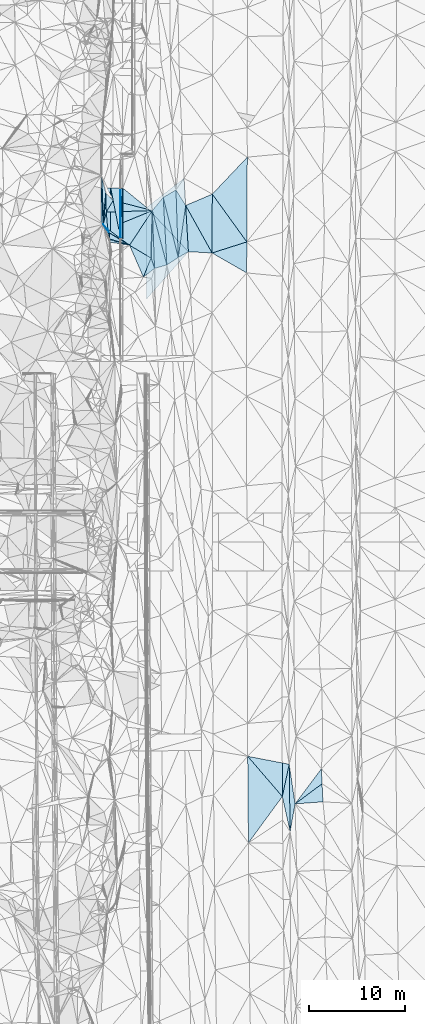
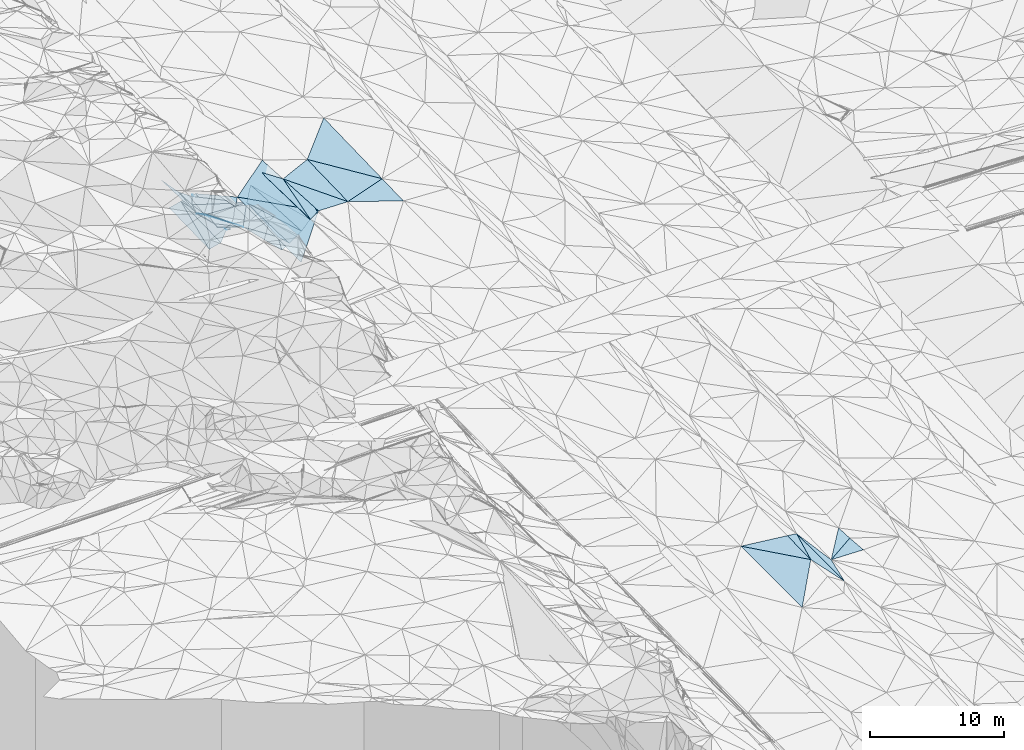
# One storey, part 90 of 275: 45 plates.
"""IFC2X3 building model written with IfcOpenShell, lengths in millimetres."""

from ifc_helpers import new_model, si_unit, frame, origin_with_axes, place, context, subcontext, project, spatial, polyline, outline, extrude, material, type_object, element, save


model = new_model("IFC2X3")

# Units and contexts
model_context = context("Model", 3, precision=1e-05, world=origin_with_axes())
body_context = subcontext(model_context, "Body", "Model", "MODEL_VIEW")
ifc_project = project(units=[si_unit("LENGTHUNIT", "METRE", prefix="MILLI"), si_unit("AREAUNIT", "SQUARE_METRE"), si_unit("VOLUMEUNIT", "CUBIC_METRE"), si_unit("MASSUNIT", "GRAM", prefix="KILO"), si_unit("TIMEUNIT", "SECOND"), si_unit("PLANEANGLEUNIT", "RADIAN"), si_unit("SOLIDANGLEUNIT", "STERADIAN"), si_unit("THERMODYNAMICTEMPERATUREUNIT", "DEGREE_CELSIUS"), si_unit("LUMINOUSINTENSITYUNIT", "LUMEN")], contexts=[model_context])

# Site, building, storey
site_placement = place(None, origin_with_axes())
site = spatial("IfcSite", under=ifc_project, at=site_placement, CompositionType="ELEMENT")
building_placement = place(site_placement, origin_with_axes())
building = spatial("IfcBuilding", under=site, at=building_placement, Name="Undefined", CompositionType="ELEMENT")
storey_placement = place(building_placement, origin_with_axes())
storey = spatial("IfcBuildingStorey", under=building, at=storey_placement, Name="Undefined", CompositionType="ELEMENT", Elevation=0.0)

# Plates
ifc_material = material()
plate_type_1 = type_object("IfcPlateType", PredefinedType="NOTDEFINED")
plate_1_placement = place(storey_placement, frame((-96851.4954738882, 99994.7714658706, 42925.1647417713), z_axis=(0.0499878488941791, 0.021723214804371, -0.998513553689431), x_axis=(-0.00635883793782182, -0.999736246119084, -0.0220681529767121)))
element("IfcPlate", 1, at=plate_1_placement, inside=storey, type_object=plate_type_1, material=ifc_material, Name="00_PR", context=body_context, shape_type="SweptSolid", body=[
    extrude(outline(polyline([(0.0, 0.0), (5080.216796875, 2.57277861237526e-08), (0.0922258049249649, 20.0247631072998), (0.0, 0.0)])), frame((-8.85201319254618e-08, 2.18876761149539e-07, -0.5000001331573), z_axis=(0.0, 0.0, 1.0), x_axis=(1.0, 0.0, 0.0)), (0.0, 0.0, 1.0), 1.0),
])
plate_2_placement = place(storey_placement, frame((-96851.4954738882, 99994.7714658706, 42925.1647417713), z_axis=(0.0499127739263493, 0.0217237749099832, -0.99851729709737), x_axis=(-0.00242106493375147, -0.999757852393647, -0.0218717859771411)))
element("IfcPlate", 2, at=plate_2_placement, inside=storey, type_object=plate_type_1, material=ifc_material, Name="00_PR", context=body_context, shape_type="SweptSolid", body=[
    extrude(outline(polyline([(0.0, 0.0), (5092.08544921875, -1.56724127009511e-08), (5080.17724609375, 20.029857635498), (0.0, 0.0)])), frame((-8.85201319254618e-08, 2.18876761149539e-07, -0.5000001331573), z_axis=(0.0, 0.0, 1.0), x_axis=(1.0, 0.0, 0.0)), (0.0, 0.0, 1.0), 1.0),
])
plate_type_2 = type_object("IfcPlateType", PredefinedType="NOTDEFINED")
plate_3_placement = place(storey_placement, frame((-76033.4313123185, 39794.5600351171, 41820.5024468965), z_axis=(-0.0990305843819008, 0.000980590525737537, -0.995083906913985), x_axis=(0.0417014085437519, -0.999116923871275, -0.00513468202207596)))
element("IfcPlate", 3, at=plate_3_placement, inside=storey, type_object=plate_type_2, material=ifc_material, Name="00", context=body_context, shape_type="SweptSolid", body=[
    extrude(outline(polyline([(0.0, 0.0), (1558.03210449219, -2.21189111471176e-09), (3523.7451171875, 2902.798828125), (0.0, 0.0)])), frame((-8.85201319254618e-08, 2.18876761149539e-07, -0.5000001331573), z_axis=(0.0, 0.0, 1.0), x_axis=(1.0, 0.0, 0.0)), (0.0, 0.0, 1.0), 1.0),
])
plate_type_3 = type_object("IfcPlateType", PredefinedType="NOTDEFINED")
plate_4_placement = place(storey_placement, frame((-90879.428268841, 92799.9130242472, 42942.5060386964), z_axis=(0.153412102929263, 0.0232033825217525, -0.987889836831198), x_axis=(-0.830745012959641, -0.538328156634387, -0.141652812246378)))
element("IfcPlate", 4, at=plate_4_placement, inside=storey, type_object=plate_type_3, material=ifc_material, Name="00", context=body_context, shape_type="SweptSolid", body=[
    extrude(outline(polyline([(0.0, 0.0), (1418.96228027344, 7.27595761418343e-09), (-2051.28784179688, 6090.20556640625), (0.0, 0.0)])), frame((-8.85201319254618e-08, 2.18876761149539e-07, -0.5000001331573), z_axis=(0.0, 0.0, 1.0), x_axis=(1.0, 0.0, 0.0)), (0.0, 0.0, 1.0), 1.0),
])
plate_type_4 = type_object("IfcPlateType", PredefinedType="NOTDEFINED")
plate_5_placement = place(storey_placement, frame((-97871.3958751985, 99997.6725906112, 42674.1790384419), z_axis=(0.242540198046966, 0.0206604415072977, -0.969921336237152), x_axis=(-0.166339082917799, -0.984082270879227, -0.0625571229777207)))
element("IfcPlate", 5, at=plate_5_placement, inside=storey, type_object=plate_type_4, material=ifc_material, Name="00_PR", context=body_context, shape_type="SweptSolid", body=[
    extrude(outline(polyline([(0.0, 0.0), (6096.44384765625, -3.32074705511332e-08), (179.178771972656, 1015.08325195313), (0.0, 0.0)])), frame((-8.85201319254618e-08, 2.18876761149539e-07, -0.5000001331573), z_axis=(0.0, 0.0, 1.0), x_axis=(1.0, 0.0, 0.0)), (0.0, 0.0, 1.0), 1.0),
])
plate_6_placement = place(storey_placement, frame((-98885.4728036614, 93998.2700633974, 42292.803035928), z_axis=(0.242520256274132, 0.0206641242565822, -0.969926244239962), x_axis=(0.166339082916099, 0.98408227087944, 0.0625571229788863)))
element("IfcPlate", 6, at=plate_6_placement, inside=storey, type_object=plate_type_4, material=ifc_material, Name="00_PR", context=body_context, shape_type="SweptSolid", body=[
    extrude(outline(polyline([(0.0, 0.0), (6096.44384765625, -3.32074705511332e-08), (180.159378051758, 1014.90979003906), (0.0, 0.0)])), frame((-8.85201319254618e-08, 2.18876761149539e-07, -0.5000001331573), z_axis=(0.0, 0.0, 1.0), x_axis=(1.0, 0.0, 0.0)), (0.0, 0.0, 1.0), 1.0),
])
plate_type_5 = type_object("IfcPlateType", PredefinedType="NOTDEFINED")
plate_7_placement = place(storey_placement, frame((-96621.4966487298, 99994.1171423472, 42936.6647417637), z_axis=(0.0499878488941791, 0.021723214804371, -0.998513553689431), x_axis=(-0.047538942919173, -0.998578492795067, -0.0241048259330112)))
element("IfcPlate", 7, at=plate_7_placement, inside=storey, type_object=plate_type_5, material=ifc_material, Name="00_PR", context=body_context, shape_type="SweptSolid", body=[
    extrude(outline(polyline([(0.0, 0.0), (5097.44384765625, 2.80706444755197e-08), (10.5577125549316, 230.044937133789), (0.0, 0.0)])), frame((-8.85201319254618e-08, 2.18876761149539e-07, -0.5000001331573), z_axis=(0.0, 0.0, 1.0), x_axis=(1.0, 0.0, 0.0)), (0.0, 0.0, 1.0), 1.0),
])
plate_8_placement = place(storey_placement, frame((-96863.8237934615, 94903.9192835579, 42813.7917395765), z_axis=(0.0498851877388846, 0.0217285145319193, -0.998518572536582), x_axis=(0.0475389429228008, 0.998578492794829, 0.0241048259357086)))
element("IfcPlate", 8, at=plate_8_placement, inside=storey, type_object=plate_type_5, material=ifc_material, Name="00_PR", context=body_context, shape_type="SweptSolid", body=[
    extrude(outline(polyline([(0.0, 0.0), (5097.44384765625, 2.80706444755197e-08), (-126.493705749512, 236.301666259766), (0.0, 0.0)])), frame((-8.85201319254618e-08, 2.18876761149539e-07, -0.5000001331573), z_axis=(0.0, 0.0, 1.0), x_axis=(1.0, 0.0, 0.0)), (0.0, 0.0, 1.0), 1.0),
])
plate_type_6 = type_object("IfcPlateType", PredefinedType="NOTDEFINED")
plate_9_placement = place(storey_placement, frame((-96883.7034717547, 94915.894183728, 42813.068037942), z_axis=(0.242539975016093, 0.0206312405021089, -0.969922013583844), x_axis=(-0.19072077902533, 0.981277901760109, -0.0268190970252547)))
element("IfcPlate", 9, at=plate_9_placement, inside=storey, type_object=plate_type_6, material=ifc_material, Name="00_PR", context=body_context, shape_type="SweptSolid", body=[
    extrude(outline(polyline([(0.0, 0.0), (5178.7353515625, -8.89849616214633e-09), (4978.51904296875, 1011.14544677734), (0.0, 0.0)])), frame((-8.85201319254618e-08, 2.18876761149539e-07, -0.5000001331573), z_axis=(0.0, 0.0, 1.0), x_axis=(1.0, 0.0, 0.0)), (0.0, 0.0, 1.0), 1.0),
])
plate_type_7 = type_object("IfcPlateType", PredefinedType="NOTDEFINED")
plate_10_placement = place(storey_placement, frame((-97885.4748056534, 93996.422001917, 42542.803058005), z_axis=(0.242696475155084, 0.0206627458977623, -0.969882194845983), x_axis=(0.00234544393031738, 0.999757718688224, 0.021886132963307)))
element("IfcPlate", 10, at=plate_10_placement, inside=storey, type_object=plate_type_7, material=ifc_material, Name="00_PR", context=body_context, shape_type="SweptSolid", body=[
    extrude(outline(polyline([(0.0, 0.0), (6002.705078125, 1.50030246004462e-08), (927.514099121094, 1030.40563964844), (0.0, 0.0)])), frame((-8.85201319254618e-08, 2.18876761149539e-07, -0.5000001331573), z_axis=(0.0, 0.0, 1.0), x_axis=(1.0, 0.0, 0.0)), (0.0, 0.0, 1.0), 1.0),
])
plate_type_8 = type_object("IfcPlateType", PredefinedType="NOTDEFINED")
plate_11_placement = place(storey_placement, frame((-90275.6695176249, 101020.000287432, 43130.1992877888), z_axis=(0.0266095090018855, 0.0212499423153103, -0.999420018802042), x_axis=(0.0588251470836311, -0.998074785881558, -0.0196551229472426)))
element("IfcPlate", 11, at=plate_11_placement, inside=storey, type_object=plate_type_8, material=ifc_material, Name="00_PR", context=body_context, shape_type="SweptSolid", body=[
    extrude(outline(polyline([(0.0, 0.0), (7633.7353515625, 1.84372765943408e-08), (2794.35400390625, 4048.16479492188), (0.0, 0.0)])), frame((-8.85201319254618e-08, 2.18876761149539e-07, -0.5000001331573), z_axis=(0.0, 0.0, 1.0), x_axis=(1.0, 0.0, 0.0)), (0.0, 0.0, 1.0), 1.0),
])
plate_type_9 = type_object("IfcPlateType", PredefinedType="NOTDEFINED")
plate_12_placement = place(storey_placement, frame((-94151.0091776219, 97995.1476947049, 42962.7033156838), z_axis=(0.0281719520292118, 0.0217993766161195, -0.999365362766797), x_axis=(-0.609228406898133, -0.792245900997221, -0.0344554869572939)))
element("IfcPlate", 12, at=plate_12_placement, inside=storey, type_object=plate_type_9, material=ifc_material, Name="00_PR", context=body_context, shape_type="SweptSolid", body=[
    extrude(outline(polyline([(0.0, 0.0), (4075.80932617188, -1.4319084584713e-08), (-77.6803970336914, 3177.08740234375), (0.0, 0.0)])), frame((-8.85201319254618e-08, 2.18876761149539e-07, -0.5000001331573), z_axis=(0.0, 0.0, 1.0), x_axis=(1.0, 0.0, 0.0)), (0.0, 0.0, 1.0), 1.0),
])
plate_type_10 = type_object("IfcPlateType", PredefinedType="NOTDEFINED")
plate_13_placement = place(storey_placement, frame((-94147.9699608055, 88514.5299228079, 42755.1683050541), z_axis=(0.0272849131028936, 0.0218858040277872, -0.999388085329731), x_axis=(-0.000320542090710549, 0.999760438789883, 0.0218852069541962)))
element("IfcPlate", 13, at=plate_13_placement, inside=storey, type_object=plate_type_10, material=ifc_material, Name="00_PR", context=body_context, shape_type="SweptSolid", body=[
    extrude(outline(polyline([(0.0, 0.0), (9482.8896484375, 3.57103999704123e-08), (4888.80029296875, 4324.53369140625), (0.0, 0.0)])), frame((-8.85201319254618e-08, 2.18876761149539e-07, -0.5000001331573), z_axis=(0.0, 0.0, 1.0), x_axis=(1.0, 0.0, 0.0)), (0.0, 0.0, 1.0), 1.0),
])
plate_type_11 = type_object("IfcPlateType", PredefinedType="NOTDEFINED")
plate_14_placement = place(storey_placement, frame((-98649.5947140472, 96242.1038516488, 44091.5713644292), z_axis=(0.422697225661851, 0.294101729878889, -0.857222974435484), x_axis=(0.568448481414877, -0.822716524468137, -0.0019606999233459)))
element("IfcPlate", 14, at=plate_14_placement, inside=storey, type_object=plate_type_11, material=ifc_material, Name="00", context=body_context, shape_type="SweptSolid", body=[
    extrude(outline(polyline([(0.0, 0.0), (1020.04364013672, 4.14729584008455e-09), (1615.89074707031, 405.54443359375), (0.0, 0.0)])), frame((-8.85201319254618e-08, 2.18876761149539e-07, -0.5000001331573), z_axis=(0.0, 0.0, 1.0), x_axis=(1.0, 0.0, 0.0)), (0.0, 0.0, 1.0), 1.0),
])
plate_type_12 = type_object("IfcPlateType", PredefinedType="NOTDEFINED")
plate_15_placement = place(storey_placement, frame((-92434.1707186344, 99034.6654672302, 42847.5066312682), z_axis=(0.160589880628025, 0.0250113536539149, -0.986704273036393), x_axis=(0.854186650649069, 0.497366704443762, 0.151629572193809)))
element("IfcPlate", 15, at=plate_15_placement, inside=storey, type_object=plate_type_12, material=ifc_material, Name="00", context=body_context, shape_type="SweptSolid", body=[
    extrude(outline(polyline([(0.0, 0.0), (1543.23461914063, -8.92032403498888e-09), (-1758.50964355469, 6181.1025390625), (0.0, 0.0)])), frame((-8.85201319254618e-08, 2.18876761149539e-07, -0.5000001331573), z_axis=(0.0, 0.0, 1.0), x_axis=(1.0, 0.0, 0.0)), (0.0, 0.0, 1.0), 1.0),
])
plate_type_13 = type_object("IfcPlateType", PredefinedType="NOTDEFINED")
plate_16_placement = place(storey_placement, frame((-98196.1666606624, 95762.4005313073, 44129.5010006608), z_axis=(0.0190056937315234, -0.0611032247328537, -0.997950489519911), x_axis=(-0.686083527377673, 0.725249145473881, -0.057472345092366)))
element("IfcPlate", 16, at=plate_16_placement, inside=storey, type_object=plate_type_13, material=ifc_material, Name="00", context=body_context, shape_type="SweptSolid", body=[
    extrude(outline(polyline([(0.0, 0.0), (661.187561035156, -3.85898601962253e-09), (1374.07299804688, 1102.73449707031), (0.0, 0.0)])), frame((-8.85201319254618e-08, 2.18876761149539e-07, -0.5000001331573), z_axis=(0.0, 0.0, 1.0), x_axis=(1.0, 0.0, 0.0)), (0.0, 0.0, 1.0), 1.0),
])
plate_type_14 = type_object("IfcPlateType", PredefinedType="NOTDEFINED")
plate_17_placement = place(storey_placement, frame((-80085.5916670394, 36916.2967845375, 42099.50017681), z_axis=(0.0189356338819722, 0.0201371554471049, -0.999617895368019), x_axis=(-0.00269947860207132, 0.999794539727684, 0.0200895780440072)))
element("IfcPlate", 17, at=plate_17_placement, inside=storey, type_object=plate_type_14, material=ifc_material, Name="00", context=body_context, shape_type="SweptSolid", body=[
    extrude(outline(polyline([(0.0, 0.0), (3484.39379882813, 8.99308361113071e-09), (3350.90991210938, 720.612976074219), (0.0, 0.0)])), frame((-8.85201319254618e-08, 2.18876761149539e-07, -0.5000001331573), z_axis=(0.0, 0.0, 1.0), x_axis=(1.0, 0.0, 0.0)), (0.0, 0.0, 1.0), 1.0),
])
plate_type_15 = type_object("IfcPlateType", PredefinedType="NOTDEFINED")
plate_18_placement = place(storey_placement, frame((-98649.9176925917, 96241.9566718011, 44091.5125962037), z_axis=(-0.223261227040327, -0.000256070140579247, -0.974758615724186), x_axis=(0.0823128983151945, 0.996423206577544, -0.0191149199495282)))
element("IfcPlate", 18, at=plate_18_placement, inside=storey, type_object=plate_type_15, material=ifc_material, Name="00", context=body_context, shape_type="SweptSolid", body=[
    extrude(outline(polyline([(0.0, 0.0), (3243.53955078125, 2.23517417907715e-08), (1295.81860351563, 212.327789306641), (0.0, 0.0)])), frame((-8.85201319254618e-08, 2.18876761149539e-07, -0.5000001331573), z_axis=(0.0, 0.0, 1.0), x_axis=(1.0, 0.0, 0.0)), (0.0, 0.0, 1.0), 1.0),
])
plate_type_16 = type_object("IfcPlateType", PredefinedType="NOTDEFINED")
plate_19_placement = place(storey_placement, frame((-90879.4937492969, 92799.9125058348, 42942.5002360059), z_axis=(0.0224678788915802, 0.022170608065339, -0.999501705129174), x_axis=(0.141197513269786, 0.989662532799849, 0.0251263490904683)))
element("IfcPlate", 19, at=plate_19_placement, inside=storey, type_object=plate_type_16, material=ifc_material, Name="00", context=body_context, shape_type="SweptSolid", body=[
    extrude(outline(polyline([(0.0, 0.0), (5452.443359375, 3.93920345231891e-08), (744.4296875, 957.60400390625), (0.0, 0.0)])), frame((-8.85201319254618e-08, 2.18876761149539e-07, -0.5000001331573), z_axis=(0.0, 0.0, 1.0), x_axis=(1.0, 0.0, 0.0)), (0.0, 0.0, 1.0), 1.0),
])
plate_type_17 = type_object("IfcPlateType", PredefinedType="NOTDEFINED")
plate_20_placement = place(storey_placement, frame((-94492.9649423907, 90773.847794996, 42619.5155002682), z_axis=(-0.245459050503838, -0.0292562782276308, -0.968965388809127), x_axis=(0.370441277422486, 0.920856099989519, -0.121644165884315)))
element("IfcPlate", 20, at=plate_20_placement, inside=storey, type_object=plate_type_17, material=ifc_material, Name="00", context=body_context, shape_type="SweptSolid", body=[
    extrude(outline(polyline([(0.0, 0.0), (2137.38159179688, -6.25732354819775e-10), (1292.49731445313, 756.409057617188), (0.0, 0.0)])), frame((-8.85201319254618e-08, 2.18876761149539e-07, -0.5000001331573), z_axis=(0.0, 0.0, 1.0), x_axis=(1.0, 0.0, 0.0)), (0.0, 0.0, 1.0), 1.0),
])
plate_type_18 = type_object("IfcPlateType", PredefinedType="NOTDEFINED")
plate_21_placement = place(storey_placement, frame((-95930.3803203107, 94074.5184665174, 43239.5391739433), z_axis=(-0.386706968819318, -0.03320444519937, -0.921604679396528), x_axis=(-0.805013531310506, 0.499692777425539, 0.319781710852481)))
element("IfcPlate", 21, at=plate_21_placement, inside=storey, type_object=plate_type_18, material=ifc_material, Name="00", context=body_context, shape_type="SweptSolid", body=[
    extrude(outline(polyline([(0.0, 0.0), (2658.06323242188, -1.880107447505e-08), (2952.18725585938, 245.746032714844), (0.0, 0.0)])), frame((-8.85201319254618e-08, 2.18876761149539e-07, -0.5000001331573), z_axis=(0.0, 0.0, 1.0), x_axis=(1.0, 0.0, 0.0)), (0.0, 0.0, 1.0), 1.0),
])
plate_type_19 = type_object("IfcPlateType", PredefinedType="NOTDEFINED")
plate_22_placement = place(storey_placement, frame((-98337.0715646821, 97515.2004035247, 44019.5253300945), z_axis=(-0.314366927923119, 0.00429933410968608, -0.949291815172971), x_axis=(0.499715744396123, 0.85097557419745, -0.1616315158685)))
element("IfcPlate", 22, at=plate_22_placement, inside=storey, type_object=plate_type_19, material=ifc_material, Name="00", context=body_context, shape_type="SweptSolid", body=[
    extrude(outline(polyline([(0.0, 0.0), (1422.98986816406, -1.76078174263239e-09), (2769.94946289063, 4202.548828125), (0.0, 0.0)])), frame((-8.85201319254618e-08, 2.18876761149539e-07, -0.5000001331573), z_axis=(0.0, 0.0, 1.0), x_axis=(1.0, 0.0, 0.0)), (0.0, 0.0, 1.0), 1.0),
])
plate_type_20 = type_object("IfcPlateType", PredefinedType="NOTDEFINED")
plate_23_placement = place(storey_placement, frame((-98382.9730452485, 99473.8937754589, 44029.5236812722), z_axis=(-0.304250806936095, -0.00226743097546864, -0.952589263657484), x_axis=(0.693996290290871, -0.685534573345628, -0.220026129835385)))
element("IfcPlate", 23, at=plate_23_placement, inside=storey, type_object=plate_type_20, material=ifc_material, Name="00", context=body_context, shape_type="SweptSolid", body=[
    extrude(outline(polyline([(0.0, 0.0), (1090.77954101563, -5.21140464115888e-09), (1376.8134765625, 1393.94567871094), (0.0, 0.0)])), frame((-8.85201319254618e-08, 2.18876761149539e-07, -0.5000001331573), z_axis=(0.0, 0.0, 1.0), x_axis=(1.0, 0.0, 0.0)), (0.0, 0.0, 1.0), 1.0),
])
plate_type_21 = type_object("IfcPlateType", PredefinedType="NOTDEFINED")
plate_24_placement = place(storey_placement, frame((-98017.5897913264, 94715.4255975981, 43879.5381074966), z_axis=(-0.179340930042034, 0.338448070933907, -0.923736831620768), x_axis=(0.917378437261553, -0.281598334416378, -0.281281319858738)))
element("IfcPlate", 24, at=plate_24_placement, inside=storey, type_object=plate_type_21, material=ifc_material, Name="00", context=body_context, shape_type="SweptSolid", body=[
    extrude(outline(polyline([(0.0, 0.0), (2275.30224609375, -1.02154444903135e-08), (179.668441772461, 305.645629882813), (0.0, 0.0)])), frame((-8.85201319254618e-08, 2.18876761149539e-07, -0.5000001331573), z_axis=(0.0, 0.0, 1.0), x_axis=(1.0, 0.0, 0.0)), (0.0, 0.0, 1.0), 1.0),
])
plate_type_22 = type_object("IfcPlateType", PredefinedType="NOTDEFINED")
plate_25_placement = place(storey_placement, frame((-90879.4892937552, 92799.9118699621, 42942.5003400387), z_axis=(0.0313641220691345, 0.0208959736422015, -0.999289572712723), x_axis=(-0.0337537855506743, 0.999233325797349, 0.0198353869881341)))
element("IfcPlate", 25, at=plate_25_placement, inside=storey, type_object=plate_type_22, material=ifc_material, Name="00", context=body_context, shape_type="SweptSolid", body=[
    extrude(outline(polyline([(0.0, 0.0), (7007.677734375, 3.8911821320653e-08), (5368.67333984375, 952.095703125), (0.0, 0.0)])), frame((-8.85201319254618e-08, 2.18876761149539e-07, -0.5000001331573), z_axis=(0.0, 0.0, 1.0), x_axis=(1.0, 0.0, 0.0)), (0.0, 0.0, 1.0), 1.0),
])
plate_type_23 = type_object("IfcPlateType", PredefinedType="NOTDEFINED")
plate_26_placement = place(storey_placement, frame((-83679.8446833976, 41089.3267892195, 42049.5004338664), z_axis=(0.0373238349353213, 0.0201763877065602, -0.999099516927536), x_axis=(0.981478516190084, -0.188734010393797, 0.0328541561752194)))
element("IfcPlate", 26, at=plate_26_placement, inside=storey, type_object=plate_type_23, material=ifc_material, Name="00", context=body_context, shape_type="SweptSolid", body=[
    extrude(outline(polyline([(0.0, 0.0), (3652.50610351563, 1.17652234621346e-08), (4316.9267578125, 3420.45971679688), (0.0, 0.0)])), frame((-8.85201319254618e-08, 2.18876761149539e-07, -0.5000001331573), z_axis=(0.0, 0.0, 1.0), x_axis=(1.0, 0.0, 0.0)), (0.0, 0.0, 1.0), 1.0),
])
plate_type_24 = type_object("IfcPlateType", PredefinedType="NOTDEFINED")
plate_27_placement = place(storey_placement, frame((-79374.1536429035, 40268.1881923376, 42180.5002223784), z_axis=(0.0240817060204962, 0.0190427497614881, -0.999528611454752), x_axis=(0.0135621845081415, -0.999732780825946, -0.0187198849726488)))
element("IfcPlate", 27, at=plate_27_placement, inside=storey, type_object=plate_type_24, material=ifc_material, Name="00", context=body_context, shape_type="SweptSolid", body=[
    extrude(outline(polyline([(0.0, 0.0), (6997.90625, 2.26573320105672e-08), (3342.86401367188, 757.061218261719), (0.0, 0.0)])), frame((-8.85201319254618e-08, 2.18876761149539e-07, -0.5000001331573), z_axis=(0.0, 0.0, 1.0), x_axis=(1.0, 0.0, 0.0)), (0.0, 0.0, 1.0), 1.0),
])
plate_type_25 = type_object("IfcPlateType", PredefinedType="NOTDEFINED")
plate_28_placement = place(storey_placement, frame((-98337.0697489859, 97515.1560691167, 44019.5266037524), z_axis=(-0.310738305127826, -0.0843663590170433, -0.946743905812176), x_axis=(0.948919039932134, 0.0298080286263581, -0.31410847980226)))
element("IfcPlate", 28, at=plate_28_placement, inside=storey, type_object=plate_type_25, material=ifc_material, Name="00", context=body_context, shape_type="SweptSolid", body=[
    extrude(outline(polyline([(0.0, 0.0), (5033.29296875, -1.68511178344488e-08), (46.7507057189941, 1761.22521972656), (0.0, 0.0)])), frame((-8.85201319254618e-08, 2.18876761149539e-07, -0.5000001331573), z_axis=(0.0, 0.0, 1.0), x_axis=(1.0, 0.0, 0.0)), (0.0, 0.0, 1.0), 1.0),
])
plate_type_26 = type_object("IfcPlateType", PredefinedType="NOTDEFINED")
plate_29_placement = place(storey_placement, frame((-92058.141845711, 92036.0509957487, 42741.5262353148), z_axis=(0.317963398408484, 0.0338635516200331, -0.947498040707317), x_axis=(-0.91225614845957, -0.261274519448484, -0.315474793105052)))
element("IfcPlate", 29, at=plate_29_placement, inside=storey, type_object=plate_type_26, material=ifc_material, Name="00", context=body_context, shape_type="SweptSolid", body=[
    extrude(outline(polyline([(0.0, 0.0), (1401.06286621094, 1.74622982740402e-09), (-4.57938051223755, 5834.11767578125), (0.0, 0.0)])), frame((-8.85201319254618e-08, 2.18876761149539e-07, -0.5000001331573), z_axis=(0.0, 0.0, 1.0), x_axis=(1.0, 0.0, 0.0)), (0.0, 0.0, 1.0), 1.0),
])
plate_type_27 = type_object("IfcPlateType", PredefinedType="NOTDEFINED")
plate_30_placement = place(storey_placement, frame((-93560.7806803671, 97665.2403059173, 42438.5029726797), z_axis=(-0.107640898675959, 0.0190189408115221, -0.994007905814959), x_axis=(0.0373763636439471, -0.999032783804082, -0.0231625630149665)))
element("IfcPlate", 30, at=plate_30_placement, inside=storey, type_object=plate_type_27, material=ifc_material, Name="00", context=body_context, shape_type="SweptSolid", body=[
    extrude(outline(polyline([(0.0, 0.0), (6001.06298828125, 1.16560840979218e-08), (4914.97021484375, 326.169006347656), (0.0, 0.0)])), frame((-8.85201319254618e-08, 2.18876761149539e-07, -0.5000001331573), z_axis=(0.0, 0.0, 1.0), x_axis=(1.0, 0.0, 0.0)), (0.0, 0.0, 1.0), 1.0),
])
plate_type_28 = type_object("IfcPlateType", PredefinedType="NOTDEFINED")
plate_31_placement = place(storey_placement, frame((-98649.9544002038, 96241.9598922644, 44091.522487426), z_axis=(-0.296575916229426, 0.00617958200956695, -0.954989287206335), x_axis=(-0.0366512435666968, 0.999168728235892, 0.0178476570026558)))
element("IfcPlate", 31, at=plate_31_placement, inside=storey, type_object=plate_type_28, material=ifc_material, Name="00", context=body_context, shape_type="SweptSolid", body=[
    extrude(outline(polyline([(0.0, 0.0), (5098.70849609375, -2.76850187219679e-08), (3218.35961914063, 403.373901367188), (0.0, 0.0)])), frame((-8.85201319254618e-08, 2.18876761149539e-07, -0.5000001331573), z_axis=(0.0, 0.0, 1.0), x_axis=(1.0, 0.0, 0.0)), (0.0, 0.0, 1.0), 1.0),
])
plate_type_29 = type_object("IfcPlateType", PredefinedType="NOTDEFINED")
plate_32_placement = place(storey_placement, frame((-98649.6570487138, 96242.0609066023, 44091.534211901), z_axis=(0.298130104071669, 0.208210326005475, -0.931540069557348), x_axis=(0.686083527316686, -0.72524914552902, 0.0574723451245978)))
element("IfcPlate", 32, at=plate_32_placement, inside=storey, type_object=plate_type_29, material=ifc_material, Name="00", context=body_context, shape_type="SweptSolid", body=[
    extrude(outline(polyline([(0.0, 0.0), (661.187561035156, -3.85898601962253e-09), (1006.33923339844, 166.644287109375), (0.0, 0.0)])), frame((-8.85201319254618e-08, 2.18876761149539e-07, -0.5000001331573), z_axis=(0.0, 0.0, 1.0), x_axis=(1.0, 0.0, 0.0)), (0.0, 0.0, 1.0), 1.0),
])
plate_type_30 = type_object("IfcPlateType", PredefinedType="NOTDEFINED")
plate_33_placement = place(storey_placement, frame((-95930.3639975991, 94074.5476165784, 43239.5325345914), z_axis=(-0.354067786176836, 0.0250949145029904, -0.93488301303314), x_axis=(0.541471896270453, 0.820550140971885, -0.183045490794772)))
element("IfcPlate", 33, at=plate_33_placement, inside=storey, type_object=plate_type_30, material=ifc_material, Name="00", context=body_context, shape_type="SweptSolid", body=[
    extrude(outline(polyline([(0.0, 0.0), (4375.96142578125, 1.29803083837032e-08), (274.741912841797, 2728.24438476563), (0.0, 0.0)])), frame((-8.85201319254618e-08, 2.18876761149539e-07, -0.5000001331573), z_axis=(0.0, 0.0, 1.0), x_axis=(1.0, 0.0, 0.0)), (0.0, 0.0, 1.0), 1.0),
])
plate_type_31 = type_object("IfcPlateType", PredefinedType="NOTDEFINED")
plate_34_placement = place(storey_placement, frame((-95930.2894420905, 94074.6708651651, 43239.5298080339), z_axis=(-0.204952536480822, 0.271592347513673, -0.940336139134347), x_axis=(-0.917378437262476, 0.281598334411352, 0.281281319860756)))
element("IfcPlate", 34, at=plate_34_placement, inside=storey, type_object=plate_type_31, material=ifc_material, Name="00", context=body_context, shape_type="SweptSolid", body=[
    extrude(outline(polyline([(0.0, 0.0), (2275.30224609375, -1.02154444903135e-08), (2576.09741210938, 654.997863769531), (0.0, 0.0)])), frame((-8.85201319254618e-08, 2.18876761149539e-07, -0.5000001331573), z_axis=(0.0, 0.0, 1.0), x_axis=(1.0, 0.0, 0.0)), (0.0, 0.0, 1.0), 1.0),
])
plate_type_32 = type_object("IfcPlateType", PredefinedType="NOTDEFINED")
plate_35_placement = place(storey_placement, frame((-95930.3653160366, 94074.5451246657, 43239.532974765), z_axis=(-0.356698997450711, 0.0201117558335373, -0.934002860003624), x_axis=(0.812940984372365, -0.485933943464254, -0.32092858787738)))
element("IfcPlate", 35, at=plate_35_placement, inside=storey, type_object=plate_type_32, material=ifc_material, Name="00", context=body_context, shape_type="SweptSolid", body=[
    extrude(outline(polyline([(0.0, 0.0), (2742.04296875, 2.37923813983798e-09), (2971.36108398438, 2125.04418945313), (0.0, 0.0)])), frame((-8.85201319254618e-08, 2.18876761149539e-07, -0.5000001331573), z_axis=(0.0, 0.0, 1.0), x_axis=(1.0, 0.0, 0.0)), (0.0, 0.0, 1.0), 1.0),
])
plate_type_33 = type_object("IfcPlateType", PredefinedType="NOTDEFINED")
plate_36_placement = place(storey_placement, frame((-98196.3515715049, 95762.44241289, 44129.5318905529), z_axis=(-0.35081474585774, 0.0226610265390312, -0.9361706532278), x_axis=(0.876526140599326, 0.359804105483713, -0.31975448475841)))
element("IfcPlate", 36, at=plate_36_placement, inside=storey, type_object=plate_type_33, material=ifc_material, Name="00", context=body_context, shape_type="SweptSolid", body=[
    extrude(outline(polyline([(0.0, 0.0), (5288.4326171875, 2.06346157938242e-08), (1663.46838378906, 2451.25952148438), (0.0, 0.0)])), frame((-8.85201319254618e-08, 2.18876761149539e-07, -0.5000001331573), z_axis=(0.0, 0.0, 1.0), x_axis=(1.0, 0.0, 0.0)), (0.0, 0.0, 1.0), 1.0),
])
plate_type_34 = type_object("IfcPlateType", PredefinedType="NOTDEFINED")
plate_37_placement = place(storey_placement, frame((-90109.621730295, 98195.9911449899, 43079.5002384487), z_axis=(0.0235561188514083, 0.0211994500393164, -0.99949772014882), x_axis=(0.91950303106459, 0.391937679776366, 0.0299838462267529)))
element("IfcPlate", 37, at=plate_37_placement, inside=storey, type_object=plate_type_34, material=ifc_material, Name="00", context=body_context, shape_type="SweptSolid", body=[
    extrude(outline(polyline([(0.0, 0.0), (3001.6162109375, 4.30736690759659e-09), (583.285766601563, 5602.9970703125), (0.0, 0.0)])), frame((-8.85201319254618e-08, 2.18876761149539e-07, -0.5000001331573), z_axis=(0.0, 0.0, 1.0), x_axis=(1.0, 0.0, 0.0)), (0.0, 0.0, 1.0), 1.0),
])
plate_type_35 = type_object("IfcPlateType", PredefinedType="NOTDEFINED")
plate_38_placement = place(storey_placement, frame((-92058.1469861383, 92036.049530829, 42741.524491097), z_axis=(0.307681096497927, 0.0309314379494943, -0.950986639761154), x_axis=(-0.257524054565574, 0.964875135892743, -0.0519358590577636)))
element("IfcPlate", 38, at=plate_38_placement, inside=storey, type_object=plate_type_35, material=ifc_material, Name="00", context=body_context, shape_type="SweptSolid", body=[
    extrude(outline(polyline([(0.0, 0.0), (5834.11962890625, -2.64044501818717e-08), (6844.1044921875, 1513.76232910156), (0.0, 0.0)])), frame((-8.85201319254618e-08, 2.18876761149539e-07, -0.5000001331573), z_axis=(0.0, 0.0, 1.0), x_axis=(1.0, 0.0, 0.0)), (0.0, 0.0, 1.0), 1.0),
])
plate_type_36 = type_object("IfcPlateType", PredefinedType="NOTDEFINED")
plate_39_placement = place(storey_placement, frame((-90109.6206891906, 98195.9917222361, 43079.5002767817), z_axis=(0.0256401899842667, 0.022356162104776, -0.99942122384584), x_axis=(0.485475442768689, -0.874221467958682, -0.00710066396285473)))
element("IfcPlate", 39, at=plate_39_placement, inside=storey, type_object=plate_type_36, material=ifc_material, Name="00", context=body_context, shape_type="SweptSolid", body=[
    extrude(outline(polyline([(0.0, 0.0), (5633.2763671875, 2.32248567044735e-08), (4330.0205078125, 2081.66381835938), (0.0, 0.0)])), frame((-8.85201319254618e-08, 2.18876761149539e-07, -0.5000001331573), z_axis=(0.0, 0.0, 1.0), x_axis=(1.0, 0.0, 0.0)), (0.0, 0.0, 1.0), 1.0),
])
plate_type_37 = type_object("IfcPlateType", PredefinedType="NOTDEFINED")
plate_40_placement = place(storey_placement, frame((-87349.6236194185, 99372.4376408485, 43169.5003106194), z_axis=(0.0293131586047292, 0.021172459994694, -0.999346018989613), x_axis=(0.585524097306185, -0.810655001510369, 1.42343285350527e-10)))
element("IfcPlate", 40, at=plate_40_placement, inside=storey, type_object=plate_type_37, material=ifc_material, Name="00", context=body_context, shape_type="SweptSolid", body=[
    extrude(outline(polyline([(0.0, 0.0), (6113.37060546875, -2.55386112257838e-09), (4931.20751953125, 3595.14819335938), (0.0, 0.0)])), frame((-8.85201319254618e-08, 2.18876761149539e-07, -0.5000001331573), z_axis=(0.0, 0.0, 1.0), x_axis=(1.0, 0.0, 0.0)), (0.0, 0.0, 1.0), 1.0),
])
plate_type_38 = type_object("IfcPlateType", PredefinedType="NOTDEFINED")
plate_41_placement = place(storey_placement, frame((-83720.3482958754, 103207.389121348, 43349.5002892751), z_axis=(0.0281115771237606, 0.0203045753402346, -0.999398550855397), x_axis=(-0.00565807335726974, -0.999774429267891, -0.0204713650728767)))
element("IfcPlate", 41, at=plate_41_placement, inside=storey, type_object=plate_type_38, material=ifc_material, Name="00", context=body_context, shape_type="SweptSolid", body=[
    extrude(outline(polyline([(0.0, 0.0), (8792.76953125, -5.1368260756135e-09), (3858.30639648438, 3608.92944335938), (0.0, 0.0)])), frame((-8.85201319254618e-08, 2.18876761149539e-07, -0.5000001331573), z_axis=(0.0, 0.0, 1.0), x_axis=(1.0, 0.0, 0.0)), (0.0, 0.0, 1.0), 1.0),
])
plate_type_39 = type_object("IfcPlateType", PredefinedType="NOTDEFINED")
plate_42_placement = place(storey_placement, frame((-83770.097907127, 94416.6034407653, 43169.5003177292), z_axis=(0.0291535411205057, 0.0216741306300728, -0.999339933707027), x_axis=(-0.00417678236267511, -0.999753518965989, -0.0218049490762107)))
element("IfcPlate", 42, at=plate_42_placement, inside=storey, type_object=plate_type_39, material=ifc_material, Name="00", context=body_context, shape_type="SweptSolid", body=[
    extrude(outline(polyline([(0.0, 0.0), (3210.2802734375, 1.087028067559e-08), (1162.95141601563, 3601.40869140625), (0.0, 0.0)])), frame((-8.85201319254618e-08, 2.18876761149539e-07, -0.5000001331573), z_axis=(0.0, 0.0, 1.0), x_axis=(1.0, 0.0, 0.0)), (0.0, 0.0, 1.0), 1.0),
])
plate_type_40 = type_object("IfcPlateType", PredefinedType="NOTDEFINED")
plate_43_placement = place(storey_placement, frame((-83604.0554854209, 32113.50011125, 41879.5004055432), z_axis=(0.0362255332232843, 0.0192297049905696, -0.999158610626293), x_axis=(-0.00844194760998315, 0.999785063482407, 0.0189356900595298)))
element("IfcPlate", 43, at=plate_43_placement, inside=storey, type_object=plate_type_40, material=ifc_material, Name="00", context=body_context, shape_type="SweptSolid", body=[
    extrude(outline(polyline([(0.0, 0.0), (8977.755859375, 2.47673597186804e-08), (4776.22705078125, 3561.25756835938), (0.0, 0.0)])), frame((-8.85201319254618e-08, 2.18876761149539e-07, -0.5000001331573), z_axis=(0.0, 0.0, 1.0), x_axis=(1.0, 0.0, 0.0)), (0.0, 0.0, 1.0), 1.0),
])
plate_type_41 = type_object("IfcPlateType", PredefinedType="NOTDEFINED")
plate_44_placement = place(storey_placement, frame((-79279.2715277291, 33272.1514193304, 42049.5002348766), z_axis=(-0.0254956939993956, 0.0183697714348722, -0.999506138592915), x_axis=(-0.0135621845392129, 0.999732780824723, 0.0187198850154286)))
element("IfcPlate", 44, at=plate_44_placement, inside=storey, type_object=plate_type_41, material=ifc_material, Name="00", context=body_context, shape_type="SweptSolid", body=[
    extrude(outline(polyline([(0.0, 0.0), (6997.90625, 2.26573320105672e-08), (2872.95776367188, 546.021179199219), (0.0, 0.0)])), frame((-8.85201319254618e-08, 2.18876761149539e-07, -0.5000001331573), z_axis=(0.0, 0.0, 1.0), x_axis=(1.0, 0.0, 0.0)), (0.0, 0.0, 1.0), 1.0),
])
plate_type_42 = type_object("IfcPlateType", PredefinedType="NOTDEFINED")
plate_45_placement = place(storey_placement, frame((-75968.4494636607, 38237.8906477881, 41812.501736511), z_axis=(-0.0795974373198119, -0.0253314923790397, -0.996505174831506), x_axis=(0.0505866205312418, -0.998491633742279, 0.0213413019729844)))
element("IfcPlate", 45, at=plate_45_placement, inside=storey, type_object=plate_type_42, material=ifc_material, Name="00", context=body_context, shape_type="SweptSolid", body=[
    extrude(outline(polyline([(0.0, 0.0), (1874.29992675781, 4.36557456851006e-09), (1946.82824707031, 2915.498046875), (0.0, 0.0)])), frame((-8.85201319254618e-08, 2.18876761149539e-07, -0.5000001331573), z_axis=(0.0, 0.0, 1.0), x_axis=(1.0, 0.0, 0.0)), (0.0, 0.0, 1.0), 1.0),
])

save(model, "model.ifc")
